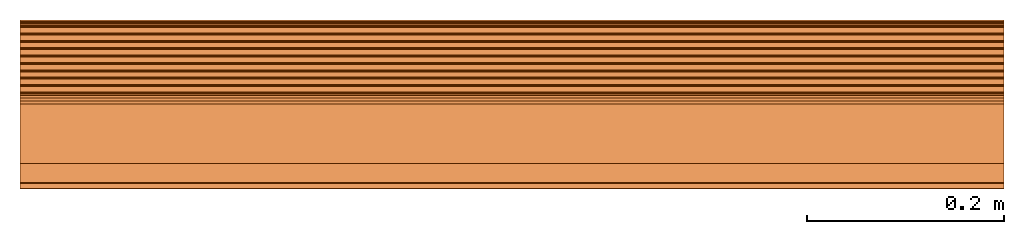
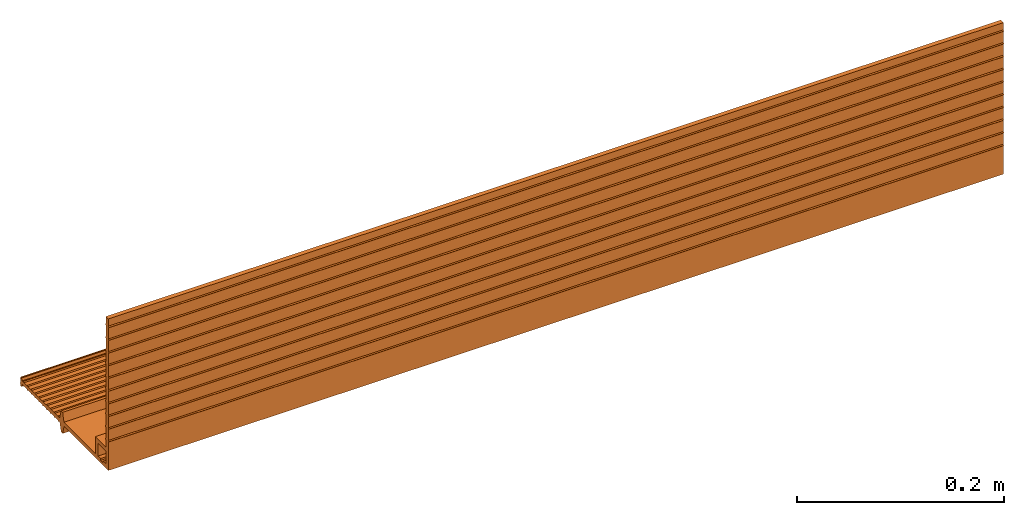
# One storey: 1 proxy.
"""IFC2X3 building model written with IfcOpenShell, lengths in millimetres."""

import ifcopenshell
import ifcopenshell.guid

model = None  # the IFC model being written
_history = None  # IfcOwnerHistory: only IFC2X3 demands one
_inside = {}  # id of a spatial element -> (the spatial element, [elements in it])
_under = {}  # id of a project, library or spatial element -> (it, [spatial elements below it])
_declared = {}  # id of a project -> (the project, [libraries it declares])
_typed = {}  # id of a type object -> (the type object, [elements of that type])
_made_of = {}  # id of a material, layer set ... -> (it, [elements and type objects made of it])


def new_model(schema):
    """Start an empty IFC model of exactly this schema.

    Asked for "IFC4X3", IfcOpenShell would pick the latest addendum, in which some entities
    have other attributes; the version numbers below select the first issue.
    IFC2X3 requires an IfcOwnerHistory on every rooted entity: one is made here for all.
    """
    global model, _history
    if schema == "IFC4X3":
        model = ifcopenshell.file(schema_version=(4, 3, 0, 0))
    else:
        model = ifcopenshell.file(schema=schema)
    _inside.clear()
    _under.clear()
    _declared.clear()
    _typed.clear()
    _made_of.clear()
    _history = None
    if model.schema == "IFC2X3":
        org = make("IfcOrganization", Name="unknown")
        user = make(
            "IfcPersonAndOrganization",
            ThePerson=make("IfcPerson", FamilyName="unknown"),
            TheOrganization=org,
        )
        app = make(
            "IfcApplication",
            ApplicationDeveloper=org,
            Version="unknown",
            ApplicationFullName="unknown",
            ApplicationIdentifier="unknown",
        )
        _history = make(
            "IfcOwnerHistory",
            OwningUser=user,
            OwningApplication=app,
            ChangeAction="ADDED",
            CreationDate=0,
        )
    return model


def make(cls, **values):
    """One entity of the class cls with the attributes given. An attribute that is None is left unset."""
    return model.create_entity(
        cls, **{name: value for name, value in values.items() if value is not None}
    )


def entity(cls, *values):
    """Any entity or typed value of the class cls, its attributes in the order of the schema. None: left unset."""
    e = model.create_entity(cls)
    for i, value in enumerate(values):
        if value is not None:
            e[i] = value
    return e


def rooted(cls, **values):
    """An entity with a GlobalId (a new one), such as an element, a storey or a relation."""
    return make(cls, GlobalId=ifcopenshell.guid.new(), OwnerHistory=_history, **values)


def si_unit(unit_type, name, prefix=None):
    """IfcSIUnit, for example si_unit("LENGTHUNIT", "METRE", prefix="MILLI")."""
    return make("IfcSIUnit", UnitType=unit_type, Prefix=prefix, Name=name)


def converted_unit(unit_type, name, factor, base, dimensions=None, offset=None):
    """IfcConversionBasedUnit, such as the inch: factor (a typed value) times the base unit."""
    return make(
        "IfcConversionBasedUnit"
        if offset is None
        else "IfcConversionBasedUnitWithOffset",
        ConversionOffset=offset,
        Dimensions=None
        if dimensions is None
        else entity("IfcDimensionalExponents", *dimensions),
        UnitType=unit_type,
        Name=name,
        ConversionFactor=make(
            "IfcMeasureWithUnit", ValueComponent=factor, UnitComponent=base
        ),
    )


def derived_unit(unit_type, elements):
    """IfcDerivedUnit: a product of units, each with its exponent."""
    return make(
        "IfcDerivedUnit",
        Elements=[
            make("IfcDerivedUnitElement", Unit=unit, Exponent=power)
            for unit, power in elements
        ],
        UnitType=unit_type,
    )


def assignment(units):
    """IfcUnitAssignment: the units of a project."""
    return None if units is None else make("IfcUnitAssignment", Units=units)


def point(xyz):
    """IfcCartesianPoint."""
    return None if xyz is None else make("IfcCartesianPoint", Coordinates=xyz)


def direction(xyz):
    """IfcDirection."""
    return None if xyz is None else make("IfcDirection", DirectionRatios=xyz)


def frame(location, z_axis=None, x_axis=None):
    """IfcAxis2Placement3D, a coordinate frame: its origin and axes. An axis left out is left unset."""
    return make(
        "IfcAxis2Placement3D",
        Location=point(location),
        Axis=direction(z_axis),
        RefDirection=direction(x_axis),
    )


def frame_2d(location, x_axis=None):
    """IfcAxis2Placement2D, a coordinate frame in the plane: its origin and x axis."""
    return make(
        "IfcAxis2Placement2D", Location=point(location), RefDirection=direction(x_axis)
    )


def origin():
    """The frame at (0, 0, 0) with its axes left unset."""
    return frame((0.0, 0.0, 0.0))


def place(relative_to, where):
    """IfcLocalPlacement: puts the frame where relative to a parent placement (None: the world)."""
    return make(
        "IfcLocalPlacement", PlacementRelTo=relative_to, RelativePlacement=where
    )


def context(
    kind, dimensions, precision=None, world=None, true_north=None, identifier=None
):
    """IfcGeometricRepresentationContext, for example the 3D "Model" context."""
    return make(
        "IfcGeometricRepresentationContext",
        ContextIdentifier=identifier,
        ContextType=kind,
        CoordinateSpaceDimension=dimensions,
        Precision=precision,
        WorldCoordinateSystem=world,
        TrueNorth=true_north,
    )


def subcontext(parent, identifier, kind, view, scale=None):
    """IfcGeometricRepresentationSubContext, for example "Body" below "Model"."""
    return make(
        "IfcGeometricRepresentationSubContext",
        ContextIdentifier=identifier,
        ContextType=kind,
        ParentContext=parent,
        TargetScale=scale,
        TargetView=view,
    )


def project(units=None, contexts=None):
    """IfcProject with its units and contexts."""
    return rooted(
        "IfcProject",
        Name="project",
        RepresentationContexts=contexts,
        UnitsInContext=assignment(units),
    )


def spatial(cls, under=None, at=None, **own):
    """A site, building, storey or space (cls), placed at a placement, below another one or the project."""
    s = rooted(cls, ObjectPlacement=at, **own)
    if under is not None:
        _under.setdefault(under.id(), (under, []))[1].append(s)
    return s


def polyline(points):
    """IfcPolyline through the points."""
    return make("IfcPolyline", Points=[point(p) for p in points])


def circle_curve(where, radius):
    """IfcCircle in the frame where."""
    return make("IfcCircle", Position=where, Radius=radius)


def parameter(value):
    """IfcParameterValue: where a trimmed curve begins or ends, as a parameter of its basis curve."""
    return model.create_entity("IfcParameterValue", value)


def trimmed(basis, trim1, trim2, sense, master):
    """IfcTrimmedCurve: the piece of a basis curve between two trims."""
    return make(
        "IfcTrimmedCurve",
        BasisCurve=basis,
        Trim1=trim1,
        Trim2=trim2,
        SenseAgreement=sense,
        MasterRepresentation=master,
    )


def segment(curve, same_sense, transition):
    """IfcCompositeCurveSegment."""
    return make(
        "IfcCompositeCurveSegment",
        Transition=transition,
        SameSense=same_sense,
        ParentCurve=curve,
    )


def composite_curve(segments, self_intersect=None):
    """IfcCompositeCurve: segments joined end to end."""
    return make("IfcCompositeCurve", Segments=segments, SelfIntersect=self_intersect)


def outline(outer, holes=None, kind="AREA"):
    """IfcArbitraryClosedProfileDef: a profile drawn as a closed curve; with holes, ...WithVoids."""
    if holes is None:
        return make("IfcArbitraryClosedProfileDef", ProfileType=kind, OuterCurve=outer)
    return make(
        "IfcArbitraryProfileDefWithVoids",
        ProfileType=kind,
        OuterCurve=outer,
        InnerCurves=holes,
    )


def extrude(swept, where, along, depth):
    """IfcExtrudedAreaSolid: the profile swept, set in the frame where, extruded along a direction by depth."""
    return make(
        "IfcExtrudedAreaSolid",
        SweptArea=swept,
        Position=where,
        ExtrudedDirection=direction(along),
        Depth=depth,
    )


def shape(context_of_items, identifier, shape_type, items):
    """IfcShapeRepresentation: the items that make up one representation, for example the "Body"."""
    return make(
        "IfcShapeRepresentation",
        ContextOfItems=context_of_items,
        RepresentationIdentifier=identifier,
        RepresentationType=shape_type,
        Items=items,
    )


def source(mapping_origin, context_of_items, identifier, shape_type, items):
    """IfcRepresentationMap: a shape defined once, which mapped items show again and again."""
    return make(
        "IfcRepresentationMap",
        MappingOrigin=mapping_origin,
        MappedRepresentation=shape(context_of_items, identifier, shape_type, items),
    )


def transform(
    local_origin,
    x_axis=None,
    y_axis=None,
    z_axis=None,
    scale=None,
    scale2=None,
    scale3=None,
    uniform=True,
):
    """IfcCartesianTransformationOperator3D, or its non-uniform kind. x_axis, y_axis, z_axis: its Axis1, 2, 3."""
    if uniform:
        return make(
            "IfcCartesianTransformationOperator3D",
            Axis1=direction(x_axis),
            Axis2=direction(y_axis),
            LocalOrigin=point(local_origin),
            Scale=scale,
            Axis3=direction(z_axis),
        )
    return make(
        "IfcCartesianTransformationOperator3DnonUniform",
        Axis1=direction(x_axis),
        Axis2=direction(y_axis),
        LocalOrigin=point(local_origin),
        Scale=scale,
        Axis3=direction(z_axis),
        Scale2=scale2,
        Scale3=scale3,
    )


def mapped(mapping_source, mapping_target):
    """IfcMappedItem: shows the shape of a source again, moved by a transform."""
    return make(
        "IfcMappedItem", MappingSource=mapping_source, MappingTarget=mapping_target
    )


def material(Name=None, Category=None):
    """IfcMaterial."""
    return make("IfcMaterial", Name=Name, Category=Category)


def made_of(thing, what):
    """Note that an element or type object is made of a material, layer set ...; save() writes the relation."""
    if what is not None:
        _made_of.setdefault(what.id(), (what, []))[1].append(thing)
    return thing


def type_object(cls, material=None, **own):
    """A type object (cls), such as IfcWallType, which elements share."""
    return made_of(rooted(cls, **own), material)


def type_shapes(of_type, sources):
    """Give a type object the sources (RepresentationMaps) that its elements show as mapped items."""
    of_type.RepresentationMaps = sources


def element(
    cls,
    number,
    at=None,
    inside=None,
    cuts=None,
    type_object=None,
    material=None,
    context=None,
    identifier="Body",
    shape_type=None,
    held_by="IfcProductDefinitionShape",
    body=None,
    shapes=None,
    **own,
):
    """One element of the class cls, such as IfcWall. Its Tag is "e" and its number.

    at: its placement. inside: the storey or other place that contains it. cuts: it is an
    opening in that element (IfcRelVoidsElement). A single representation is given by context,
    identifier, shape_type and body (its items); several are given by shapes. held_by: the class
    of the entity that holds the representations. save() writes the other relations.
    """
    e = rooted(cls, Tag="e%d" % number, ObjectPlacement=at, **own)
    if body is not None:
        shapes = [shape(context, identifier, shape_type, body)]
    if shapes is not None:
        e.Representation = make(held_by, Representations=shapes)
    if inside is not None:
        _inside.setdefault(inside.id(), (inside, []))[1].append(e)
    if cuts is not None:
        rooted(
            "IfcRelVoidsElement", RelatingBuildingElement=cuts, RelatedOpeningElement=e
        )
    if type_object is not None:
        _typed.setdefault(type_object.id(), (type_object, []))[1].append(e)
    return made_of(e, material)


def aggregate(whole, parts):
    """IfcRelAggregates: a whole, such as a stair, and the parts it consists of."""
    return rooted("IfcRelAggregates", RelatingObject=whole, RelatedObjects=parts)


def save(model, path):
    """Write the relations noted so far, then the file.

    IfcRelAggregates (storeys below a building ...), IfcRelContainedInSpatialStructure (elements
    in a storey), IfcRelDefinesByType, IfcRelAssociatesMaterial and IfcRelDeclares: one each for
    every whole, place, type object, material and project.
    """
    for whole, parts in _under.values():
        aggregate(whole, parts)
    for where, things in _inside.values():
        rooted(
            "IfcRelContainedInSpatialStructure",
            RelatedElements=things,
            RelatingStructure=where,
        )
    for kind, things in _typed.values():
        rooted("IfcRelDefinesByType", RelatedObjects=things, RelatingType=kind)
    for what, things in _made_of.values():
        rooted("IfcRelAssociatesMaterial", RelatedObjects=things, RelatingMaterial=what)
    for by, libraries in _declared.values():
        rooted("IfcRelDeclares", RelatingContext=by, RelatedDefinitions=libraries)
    model.write(path)


model = new_model("IFC2X3")

# Units and contexts
model_context = context("Model", 3, precision=0.01, world=origin(), true_north=direction((6.12303176911189e-17, 1.0)))
body_context = subcontext(model_context, "Body", "Model", "MODEL_VIEW")
ifc_project = project(units=[si_unit("LENGTHUNIT", "METRE", prefix="MILLI"), si_unit("AREAUNIT", "SQUARE_METRE"), si_unit("VOLUMEUNIT", "CUBIC_METRE"), converted_unit("PLANEANGLEUNIT", "DEGREE", entity("IfcRatioMeasure", 0.0174532925199433), si_unit("PLANEANGLEUNIT", "RADIAN"), dimensions=[0, 0, 0, 0, 0, 0, 0]), si_unit("MASSUNIT", "GRAM", prefix="KILO"), derived_unit("MASSDENSITYUNIT", [(si_unit("MASSUNIT", "GRAM", prefix="KILO"), 1), (si_unit("LENGTHUNIT", "METRE"), -3)]), derived_unit("MOMENTOFINERTIAUNIT", [(si_unit("LENGTHUNIT", "METRE"), 4)]), si_unit("TIMEUNIT", "SECOND"), si_unit("FREQUENCYUNIT", "HERTZ"), si_unit("THERMODYNAMICTEMPERATUREUNIT", "DEGREE_CELSIUS"), derived_unit("THERMALTRANSMITTANCEUNIT", [(si_unit("MASSUNIT", "GRAM", prefix="KILO"), 1), (si_unit("THERMODYNAMICTEMPERATUREUNIT", "KELVIN"), -1), (si_unit("TIMEUNIT", "SECOND"), -3)]), derived_unit("VOLUMETRICFLOWRATEUNIT", [(si_unit("LENGTHUNIT", "METRE"), 3), (si_unit("TIMEUNIT", "SECOND"), -1)]), si_unit("ELECTRICCURRENTUNIT", "AMPERE"), si_unit("ELECTRICVOLTAGEUNIT", "VOLT"), si_unit("POWERUNIT", "WATT"), si_unit("FORCEUNIT", "NEWTON", prefix="KILO"), si_unit("ILLUMINANCEUNIT", "LUX"), si_unit("LUMINOUSFLUXUNIT", "LUMEN"), si_unit("LUMINOUSINTENSITYUNIT", "CANDELA"), derived_unit("USERDEFINED", [(si_unit("MASSUNIT", "GRAM", prefix="KILO"), -1), (si_unit("LENGTHUNIT", "METRE"), -2), (si_unit("TIMEUNIT", "SECOND"), 3), (si_unit("LUMINOUSFLUXUNIT", "LUMEN"), 1)]), derived_unit("LINEARVELOCITYUNIT", [(si_unit("LENGTHUNIT", "METRE"), 1), (si_unit("TIMEUNIT", "SECOND"), -1)]), si_unit("PRESSUREUNIT", "PASCAL"), derived_unit("USERDEFINED", [(si_unit("LENGTHUNIT", "METRE"), -2), (si_unit("MASSUNIT", "GRAM", prefix="KILO"), 1), (si_unit("TIMEUNIT", "SECOND"), -2)]), derived_unit("LINEARFORCEUNIT", [(si_unit("MASSUNIT", "GRAM", prefix="KILO"), 1), (si_unit("LENGTHUNIT", "METRE"), 1), (si_unit("TIMEUNIT", "SECOND"), -2), (si_unit("LENGTHUNIT", "METRE"), -1)]), derived_unit("PLANARFORCEUNIT", [(si_unit("MASSUNIT", "GRAM", prefix="KILO"), 1), (si_unit("LENGTHUNIT", "METRE"), 1), (si_unit("TIMEUNIT", "SECOND"), -2), (si_unit("LENGTHUNIT", "METRE"), -2)])], contexts=[model_context])

# Site, building, storey
site_placement = place(None, origin())
site = spatial("IfcSite", under=ifc_project, at=site_placement, CompositionType="ELEMENT")
building_placement = place(site_placement, origin())
building = spatial("IfcBuilding", under=site, at=building_placement, CompositionType="ELEMENT")
storey_placement = place(building_placement, origin())
storey = spatial("IfcBuildingStorey", under=building, at=storey_placement, Name="Level 0", CompositionType="ELEMENT", Elevation=0.0)

# Proxy
ifc_material = material()
building_element_proxy_type = type_object("IfcBuildingElementProxyType", PredefinedType="NOTDEFINED", material=ifc_material)
shared_shape = source(origin(), body_context, "Body", "SweptSolid", [
    extrude(outline(composite_curve([segment(trimmed(circle_curve(frame_2d((93.5182958419337, 38.527027027027), x_axis=(1.0, 0.0)), 1.00000000000001), [parameter(195.304846468823)], [parameter(276.802397936778)], True, "PARAMETER"), True, "CONTINUOUS"), segment(trimmed(circle_curve(frame_2d((93.7551868933097, 38.527027027027), x_axis=(1.0, 0.0)), 1.00000000000001), [parameter(263.197602063222)], [parameter(0.0)], True, "PARAMETER"), True, "CONTINUOUS"), segment(polyline([(94.7551868933097, 38.527027027027), (94.7551868933097, 39.527027027027)]), True, "CONTINUOUS"), segment(polyline([(94.7551868933097, 39.527027027027), (95.7551868933097, 40.527027027027)]), True, "CONTINUOUS"), segment(polyline([(95.7551868933097, 40.527027027027), (94.7551868933097, 41.527027027027)]), True, "CONTINUOUS"), segment(polyline([(94.7551868933097, 41.527027027027), (94.7551868933097, 44.527027027027)]), True, "CONTINUOUS"), segment(polyline([(94.7551868933097, 44.527027027027), (95.7551868933097, 45.527027027027)]), True, "CONTINUOUS"), segment(polyline([(95.7551868933097, 45.527027027027), (94.7551868933097, 46.527027027027)]), True, "CONTINUOUS"), segment(polyline([(94.7551868933097, 46.527027027027), (94.7551868933097, 47.527027027027)]), True, "CONTINUOUS"), segment(trimmed(circle_curve(frame_2d((93.7551868933097, 47.527027027027), x_axis=(1.0, 0.0)), 1.00000000000001), [parameter(2.03555499613665e-13)], [parameter(96.8023979367777)], True, "PARAMETER"), True, "CONTINUOUS"), segment(trimmed(circle_curve(frame_2d((93.5182958419337, 47.527027027027), x_axis=(1.0, 0.0)), 1.00000000000001), [parameter(83.1976020632224)], [parameter(164.695153531177)], True, "PARAMETER"), True, "CONTINUOUS"), segment(polyline([(92.5537607471148, 47.7909816649122), (91.797377024539, 45.027027027027)]), True, "CONTINUOUS"), segment(polyline([(91.797377024539, 45.027027027027), (90.1152097596769, 45.0385704319942)]), True, "CONTINUOUS"), segment(polyline([(90.1152097596769, 45.0385704319942), (89.1220953641769, 46.0454089480699)]), True, "CONTINUOUS"), segment(polyline([(89.1220953641769, 46.0454089480699), (88.1152568480994, 45.0522945525717)]), True, "CONTINUOUS"), segment(polyline([(88.1152568480994, 45.0522945525717), (82.6153863412711, 45.0900358841594)]), True, "CONTINUOUS"), segment(polyline([(82.6153863412711, 45.0900358841594), (81.622271945771, 46.0968744002352)]), True, "CONTINUOUS"), segment(polyline([(81.622271945771, 46.0968744002352), (80.6154334296971, 45.103760004737)]), True, "CONTINUOUS"), segment(polyline([(80.6154334296971, 45.103760004737), (75.1155629228689, 45.1415013363248)]), True, "CONTINUOUS"), segment(polyline([(75.1155629228689, 45.1415013363248), (74.1224485273688, 46.1483398524005)]), True, "CONTINUOUS"), segment(polyline([(74.1224485273688, 46.1483398524005), (73.1156100112949, 45.1552254569023)]), True, "CONTINUOUS"), segment(polyline([(73.1156100112949, 45.1552254569023), (67.6157395044666, 45.1929667884901)]), True, "CONTINUOUS"), segment(polyline([(67.6157395044666, 45.1929667884901), (66.622625108963, 46.1998053045658)]), True, "CONTINUOUS"), segment(polyline([(66.622625108963, 46.1998053045658), (65.615786592889, 45.2066909090676)]), True, "CONTINUOUS"), segment(polyline([(65.615786592889, 45.2066909090676), (60.1159160860607, 45.2444322406554)]), True, "CONTINUOUS"), segment(polyline([(60.1159160860607, 45.2444322406554), (59.1228016905607, 46.2512707567311)]), True, "CONTINUOUS"), segment(polyline([(59.1228016905607, 46.2512707567311), (58.1159631744868, 45.2581563612329)]), True, "CONTINUOUS"), segment(polyline([(58.1159631744868, 45.2581563612329), (52.6160926676585, 45.2958976928207)]), True, "CONTINUOUS"), segment(polyline([(52.6160926676585, 45.2958976928207), (51.6229782721585, 46.3027362088964)]), True, "CONTINUOUS"), segment(polyline([(51.6229782721585, 46.3027362088964), (50.6161397560846, 45.3096218133977)]), True, "CONTINUOUS"), segment(polyline([(50.6161397560846, 45.3096218133977), (45.1162692492526, 45.347363144986)]), True, "CONTINUOUS"), segment(polyline([(45.1162692492526, 45.347363144986), (44.1231548537526, 46.3542016610617)]), True, "CONTINUOUS"), segment(polyline([(44.1231548537526, 46.3542016610617), (43.1163163376787, 45.361087265563)]), True, "CONTINUOUS"), segment(polyline([(43.1163163376787, 45.361087265563), (37.6164458308504, 45.3988285971513)]), True, "CONTINUOUS"), segment(polyline([(37.6164458308504, 45.3988285971513), (36.6233314353504, 46.405667113227)]), True, "CONTINUOUS"), segment(polyline([(36.6233314353504, 46.405667113227), (35.6164929192765, 45.4125527177283)]), True, "CONTINUOUS"), segment(polyline([(35.6164929192765, 45.4125527177283), (30.1166224124482, 45.4502940493166)]), True, "CONTINUOUS"), segment(polyline([(30.1166224124482, 45.4502940493166), (29.1235080169482, 46.4571325653918)]), True, "CONTINUOUS"), segment(polyline([(29.1235080169482, 46.4571325653918), (28.1166695008742, 45.4640181698936)]), True, "CONTINUOUS"), segment(polyline([(28.1166695008742, 45.4640181698936), (22.6167989940423, 45.5017595014819)]), True, "CONTINUOUS"), segment(polyline([(22.6167989940423, 45.5017595014819), (21.6236845985423, 46.5085980175572)]), True, "CONTINUOUS"), segment(polyline([(21.6236845985423, 46.5085980175572), (20.6168460824684, 45.515483622059)]), True, "CONTINUOUS"), segment(polyline([(20.6168460824684, 45.515483622059), (18.9346788176063, 45.5270270270261)]), True, "CONTINUOUS"), segment(polyline([(18.9346788176063, 45.5270270270261), (16.2551868933097, 55.527027027027)]), True, "CONTINUOUS"), segment(polyline([(16.2551868933097, 55.527027027027), (13.2551868933097, 55.527027027027)]), True, "CONTINUOUS"), segment(polyline([(13.2551868933097, 55.527027027027), (10.5756949689913, 45.5270270270279)]), True, "CONTINUOUS"), segment(polyline([(10.5756949689913, 45.5270270270279), (-75.2448131066903, 45.527027027027)]), True, "CONTINUOUS"), segment(polyline([(-75.2448131066903, 45.527027027027), (-75.2448131066904, 12.027027027027)]), True, "CONTINUOUS"), segment(polyline([(-75.2448131066904, 12.027027027027), (-76.2448131066903, 11.027027027027)]), True, "CONTINUOUS"), segment(polyline([(-76.2448131066903, 11.027027027027), (-75.2448131066904, 10.027027027027)]), True, "CONTINUOUS"), segment(polyline([(-75.2448131066904, 10.027027027027), (-75.2448131066904, -2.97297297297301)]), True, "CONTINUOUS"), segment(polyline([(-75.2448131066904, -2.97297297297301), (-76.2448131066903, -3.97297297297301)]), True, "CONTINUOUS"), segment(polyline([(-76.2448131066903, -3.97297297297301), (-75.2448131066904, -4.97297297297301)]), True, "CONTINUOUS"), segment(polyline([(-75.2448131066904, -4.97297297297301), (-75.2448131066903, -17.972972972973)]), True, "CONTINUOUS"), segment(polyline([(-75.2448131066903, -17.972972972973), (-76.2448131066903, -18.972972972973)]), True, "CONTINUOUS"), segment(polyline([(-76.2448131066903, -18.972972972973), (-75.2448131066903, -19.972972972973)]), True, "CONTINUOUS"), segment(polyline([(-75.2448131066903, -19.972972972973), (-75.2448131066903, -32.972972972973)]), True, "CONTINUOUS"), segment(polyline([(-75.2448131066903, -32.972972972973), (-76.2448131066903, -33.972972972973)]), True, "CONTINUOUS"), segment(polyline([(-76.2448131066903, -33.972972972973), (-75.2448131066904, -34.972972972973)]), True, "CONTINUOUS"), segment(polyline([(-75.2448131066904, -34.972972972973), (-75.2448131066903, -47.972972972973)]), True, "CONTINUOUS"), segment(polyline([(-75.2448131066903, -47.972972972973), (-76.2448131066903, -48.972972972973)]), True, "CONTINUOUS"), segment(polyline([(-76.2448131066903, -48.972972972973), (-75.2448131066904, -49.972972972973)]), True, "CONTINUOUS"), segment(polyline([(-75.2448131066904, -49.972972972973), (-75.2448131066903, -62.972972972973)]), True, "CONTINUOUS"), segment(polyline([(-75.2448131066903, -62.972972972973), (-76.2448131066904, -63.972972972973)]), True, "CONTINUOUS"), segment(polyline([(-76.2448131066904, -63.972972972973), (-75.2448131066903, -64.9729729729731)]), True, "CONTINUOUS"), segment(polyline([(-75.2448131066903, -64.9729729729731), (-75.2448131066904, -77.972972972973)]), True, "CONTINUOUS"), segment(polyline([(-75.2448131066904, -77.972972972973), (-76.2448131066904, -78.972972972973)]), True, "CONTINUOUS"), segment(polyline([(-76.2448131066904, -78.972972972973), (-75.2448131066903, -79.972972972973)]), True, "CONTINUOUS"), segment(polyline([(-75.2448131066903, -79.972972972973), (-75.2448131066904, -92.972972972973)]), True, "CONTINUOUS"), segment(polyline([(-75.2448131066904, -92.972972972973), (-76.2448131066903, -93.972972972973)]), True, "CONTINUOUS"), segment(polyline([(-76.2448131066903, -93.972972972973), (-75.2448131066903, -94.972972972973)]), True, "CONTINUOUS"), segment(polyline([(-75.2448131066903, -94.972972972973), (-75.2448131066904, -107.972972972973)]), True, "CONTINUOUS"), segment(polyline([(-75.2448131066904, -107.972972972973), (-76.2448131066903, -108.972972972973)]), True, "CONTINUOUS"), segment(polyline([(-76.2448131066903, -108.972972972973), (-75.2448131066903, -109.972972972973)]), True, "CONTINUOUS"), segment(polyline([(-75.2448131066903, -109.972972972973), (-75.2448131066903, -122.972972972973)]), True, "CONTINUOUS"), segment(polyline([(-75.2448131066903, -122.972972972973), (-76.2448131066903, -123.972972972973)]), True, "CONTINUOUS"), segment(polyline([(-76.2448131066903, -123.972972972973), (-75.2448131066903, -124.972972972973)]), True, "CONTINUOUS"), segment(polyline([(-75.2448131066903, -124.972972972973), (-75.2448131066939, -133.472972972973)]), True, "CONTINUOUS"), segment(polyline([(-75.2448131066939, -133.472972972973), (-70.2448131066867, -133.472972972973)]), True, "CONTINUOUS"), segment(polyline([(-70.2448131066867, -133.472972972973), (-70.2448131066903, -124.972972972973)]), True, "CONTINUOUS"), segment(polyline([(-70.2448131066903, -124.972972972973), (-69.2448131066903, -123.972972972973)]), True, "CONTINUOUS"), segment(polyline([(-69.2448131066903, -123.972972972973), (-70.2448131066903, -122.972972972973)]), True, "CONTINUOUS"), segment(polyline([(-70.2448131066903, -122.972972972973), (-70.2448131066903, -109.972972972973)]), True, "CONTINUOUS"), segment(polyline([(-70.2448131066903, -109.972972972973), (-69.2448131066903, -108.972972972973)]), True, "CONTINUOUS"), segment(polyline([(-69.2448131066903, -108.972972972973), (-70.2448131066903, -107.972972972973)]), True, "CONTINUOUS"), segment(polyline([(-70.2448131066903, -107.972972972973), (-70.2448131066903, -94.972972972973)]), True, "CONTINUOUS"), segment(polyline([(-70.2448131066903, -94.972972972973), (-69.2448131066903, -93.972972972973)]), True, "CONTINUOUS"), segment(polyline([(-69.2448131066903, -93.972972972973), (-70.2448131066903, -92.972972972973)]), True, "CONTINUOUS"), segment(polyline([(-70.2448131066903, -92.972972972973), (-70.2448131066903, -79.972972972973)]), True, "CONTINUOUS"), segment(polyline([(-70.2448131066903, -79.972972972973), (-69.2448131066903, -78.972972972973)]), True, "CONTINUOUS"), segment(polyline([(-69.2448131066903, -78.972972972973), (-70.2448131066903, -77.972972972973)]), True, "CONTINUOUS"), segment(polyline([(-70.2448131066903, -77.972972972973), (-70.2448131066903, -64.9729729729731)]), True, "CONTINUOUS"), segment(polyline([(-70.2448131066903, -64.9729729729731), (-69.2448131066903, -63.972972972973)]), True, "CONTINUOUS"), segment(polyline([(-69.2448131066903, -63.972972972973), (-70.2448131066903, -62.972972972973)]), True, "CONTINUOUS"), segment(polyline([(-70.2448131066903, -62.972972972973), (-70.2448131066903, -49.972972972973)]), True, "CONTINUOUS"), segment(polyline([(-70.2448131066903, -49.972972972973), (-69.2448131066903, -48.972972972973)]), True, "CONTINUOUS"), segment(polyline([(-69.2448131066903, -48.972972972973), (-70.2448131066903, -47.972972972973)]), True, "CONTINUOUS"), segment(polyline([(-70.2448131066903, -47.972972972973), (-70.2448131066903, -34.972972972973)]), True, "CONTINUOUS"), segment(polyline([(-70.2448131066903, -34.972972972973), (-69.2448131066903, -33.972972972973)]), True, "CONTINUOUS"), segment(polyline([(-69.2448131066903, -33.972972972973), (-70.2448131066903, -32.972972972973)]), True, "CONTINUOUS"), segment(polyline([(-70.2448131066903, -32.972972972973), (-70.2448131066903, -19.972972972973)]), True, "CONTINUOUS"), segment(polyline([(-70.2448131066903, -19.972972972973), (-69.2448131066903, -18.972972972973)]), True, "CONTINUOUS"), segment(polyline([(-69.2448131066903, -18.972972972973), (-70.2448131066903, -17.972972972973)]), True, "CONTINUOUS"), segment(polyline([(-70.2448131066903, -17.972972972973), (-70.2448131066903, -4.972972972973)]), True, "CONTINUOUS"), segment(polyline([(-70.2448131066903, -4.972972972973), (-69.2448131066903, -3.972972972973)]), True, "CONTINUOUS"), segment(polyline([(-69.2448131066903, -3.972972972973), (-70.2448131066903, -2.97297297297301)]), True, "CONTINUOUS"), segment(polyline([(-70.2448131066903, -2.97297297297301), (-70.2448131066903, 10.027027027027)]), True, "CONTINUOUS"), segment(polyline([(-70.2448131066903, 10.027027027027), (-69.2448131066903, 11.027027027027)]), True, "CONTINUOUS"), segment(polyline([(-69.2448131066903, 11.027027027027), (-70.2448131066903, 12.027027027027)]), True, "CONTINUOUS"), segment(polyline([(-70.2448131066903, 12.027027027027), (-70.2448131066903, 20.527027027027)]), True, "CONTINUOUS"), segment(polyline([(-70.2448131066903, 20.527027027027), (-50.2448131066867, 20.527027027027)]), True, "CONTINUOUS"), segment(polyline([(-50.2448131066867, 20.527027027027), (-50.2448131066867, 40.527027027027)]), True, "CONTINUOUS"), segment(polyline([(-50.2448131066867, 40.527027027027), (10.5756949690022, 40.5270270270279)]), True, "CONTINUOUS"), segment(polyline([(10.5756949690022, 40.5270270270279), (13.2551868933097, 30.527027027027)]), True, "CONTINUOUS"), segment(polyline([(13.2551868933097, 30.527027027027), (16.2551868933097, 30.527027027027)]), True, "CONTINUOUS"), segment(polyline([(16.2551868933097, 30.527027027027), (18.9346788176063, 40.5270270270279)]), True, "CONTINUOUS"), segment(polyline([(18.9346788176063, 40.5270270270279), (20.6168460824684, 40.5385704319951)]), True, "CONTINUOUS"), segment(polyline([(20.6168460824684, 40.5385704319951), (21.6236845985423, 39.5454560364969)]), True, "CONTINUOUS"), segment(polyline([(21.6236845985423, 39.5454560364969), (22.6167989940423, 40.5522945525721)]), True, "CONTINUOUS"), segment(polyline([(22.6167989940423, 40.5522945525721), (28.1166695008742, 40.5900358841604)]), True, "CONTINUOUS"), segment(polyline([(28.1166695008742, 40.5900358841604), (29.1235080169482, 39.5969214886622)]), True, "CONTINUOUS"), segment(polyline([(29.1235080169482, 39.5969214886622), (30.1166224124482, 40.6037600047374)]), True, "CONTINUOUS"), segment(polyline([(30.1166224124482, 40.6037600047374), (35.6164929192765, 40.6415013363257)]), True, "CONTINUOUS"), segment(polyline([(35.6164929192765, 40.6415013363257), (36.6233314353504, 39.648386940827)]), True, "CONTINUOUS"), segment(polyline([(36.6233314353504, 39.648386940827), (37.6164458308504, 40.6552254569027)]), True, "CONTINUOUS"), segment(polyline([(37.6164458308504, 40.6552254569027), (43.1163163376787, 40.692966788491)]), True, "CONTINUOUS"), segment(polyline([(43.1163163376787, 40.692966788491), (44.1231548537526, 39.6998523929923)]), True, "CONTINUOUS"), segment(polyline([(44.1231548537526, 39.6998523929923), (45.1162692492526, 40.706690909068)]), True, "CONTINUOUS"), segment(polyline([(45.1162692492526, 40.706690909068), (50.6161397560846, 40.7444322406563)]), True, "CONTINUOUS"), segment(polyline([(50.6161397560846, 40.7444322406563), (51.6229782721585, 39.7513178451576)]), True, "CONTINUOUS"), segment(polyline([(51.6229782721585, 39.7513178451576), (52.6160926676585, 40.7581563612333)]), True, "CONTINUOUS"), segment(polyline([(52.6160926676585, 40.7581563612333), (58.1159631744868, 40.7958976928211)]), True, "CONTINUOUS"), segment(polyline([(58.1159631744868, 40.7958976928211), (59.1228016905607, 39.8027832973229)]), True, "CONTINUOUS"), segment(polyline([(59.1228016905607, 39.8027832973229), (60.1159160860607, 40.8096218133987)]), True, "CONTINUOUS"), segment(polyline([(60.1159160860607, 40.8096218133987), (65.615786592889, 40.8473631449864)]), True, "CONTINUOUS"), segment(polyline([(65.615786592889, 40.8473631449864), (66.622625108963, 39.8542487494882)]), True, "CONTINUOUS"), segment(polyline([(66.622625108963, 39.8542487494882), (67.6157395044666, 40.861087265564)]), True, "CONTINUOUS"), segment(polyline([(67.6157395044666, 40.861087265564), (73.1156100112949, 40.8988285971517)]), True, "CONTINUOUS"), segment(polyline([(73.1156100112949, 40.8988285971517), (74.1224485273688, 39.9057142016535)]), True, "CONTINUOUS"), segment(polyline([(74.1224485273688, 39.9057142016535), (75.1155629228689, 40.9125527177293)]), True, "CONTINUOUS"), segment(polyline([(75.1155629228689, 40.9125527177293), (80.6154334296972, 40.950294049317)]), True, "CONTINUOUS"), segment(polyline([(80.6154334296972, 40.950294049317), (81.622271945771, 39.9571796538188)]), True, "CONTINUOUS"), segment(polyline([(81.622271945771, 39.9571796538188), (82.6153863412711, 40.9640181698946)]), True, "CONTINUOUS"), segment(polyline([(82.6153863412711, 40.9640181698946), (88.1152568480994, 41.0017595014823)]), True, "CONTINUOUS"), segment(polyline([(88.1152568480994, 41.0017595014823), (89.1220953641769, 40.0086451059841)]), True, "CONTINUOUS"), segment(polyline([(89.1220953641769, 40.0086451059841), (90.1152097596769, 41.0154836220599)]), True, "CONTINUOUS"), segment(polyline([(90.1152097596769, 41.0154836220599), (91.797377024539, 41.027027027027)]), True, "CONTINUOUS"), segment(polyline([(91.797377024539, 41.027027027027), (92.5537607471135, 38.2630723891436)]), True, "CONTINUOUS")], self_intersect=False), holes=[polyline([(-70.2448131066903, 40.527027027027), (-65.2448131066903, 40.527027027027), (-65.2448131066903, 42.527027027027), (-60.2448131066903, 42.5270270270279), (-60.2448131066903, 40.527027027027), (-55.2448131066903, 40.527027027027), (-55.2448131066867, 25.5270270270279), (-70.2448131066903, 25.5270270270279), (-70.2448131066903, 40.527027027027)])]), frame((75.2448131066903, -1000.0, 45.527027027027), z_axis=(0.0, 1.0, 0.0), x_axis=(1.0, 0.0, 0.0)), (0.0, 0.0, 1.0), 1000.0),
])
type_shapes(building_element_proxy_type, [shared_shape])
proxy_placement = place(storey_placement, frame((17954.7586493606, 2418.31735559892, 0.0), z_axis=(0.0, 0.0, 1.0), x_axis=(0.0, 1.0, 0.0)))
element("IfcBuildingElementProxy", 1, at=proxy_placement, inside=storey, type_object=building_element_proxy_type, material=ifc_material, Name="606217", context=body_context, shape_type="MappedRepresentation", body=[
    mapped(shared_shape, transform((0.0, 0.0, 0.0), scale=1.0)),
])

save(model, "model.ifc")
